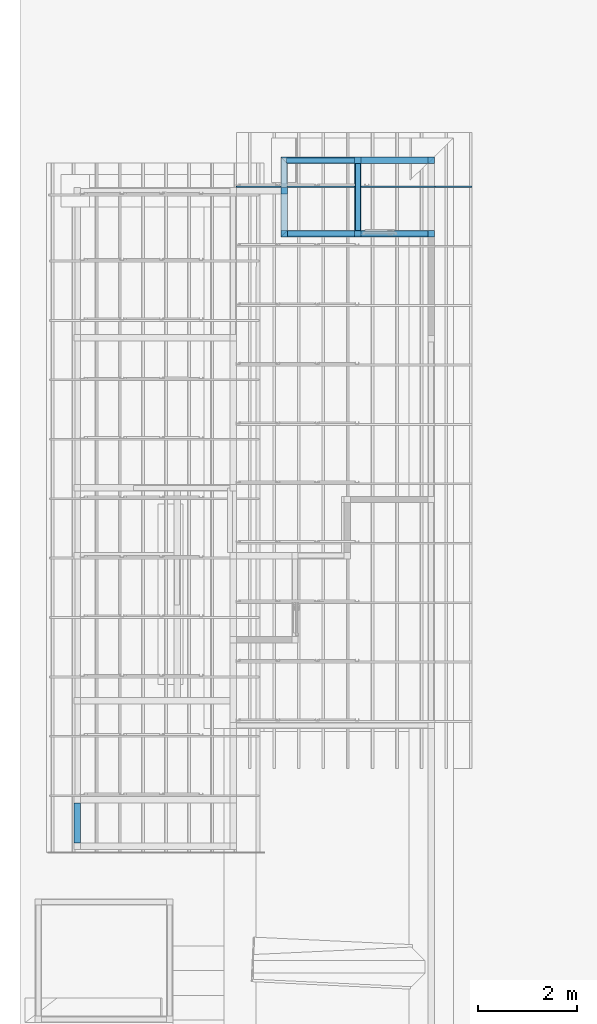
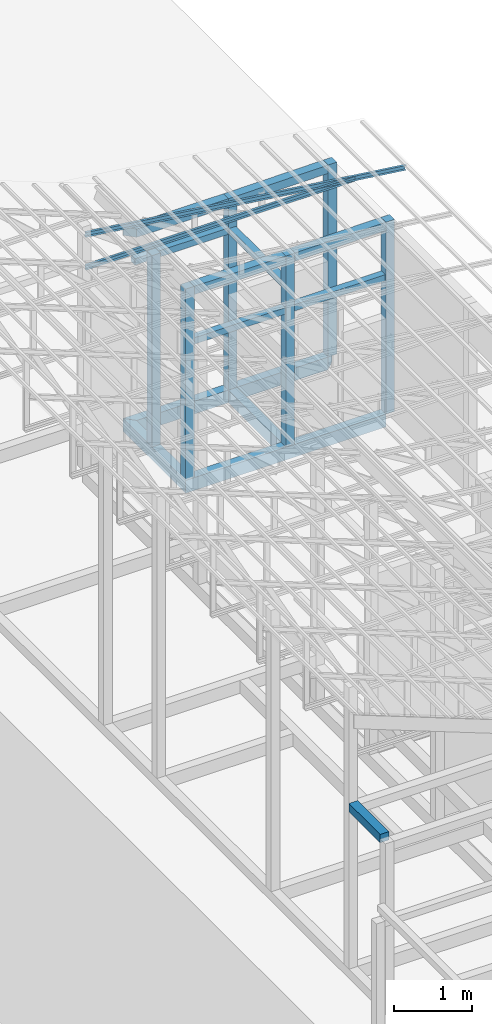
# One storey, part 15 of 22: 18 beams, 2 members, 1 element without a shape of its own.
"""IFC4 building model written with IfcOpenShell, lengths in millimetres."""

from ifc_helpers import new_model, entity, si_unit, converted_unit, frame, origin_with_axes, origin_2d_with_axis, place, context, subcontext, project, spatial, indexed_curve, rectangle, c_section, outline, extrude, clip, halfspace, material, material_profile, profile_set, profile_usage, type_object, element, aggregate, save


model = new_model("IFC4")

# Units and contexts
model_context = context("Model", 3, precision=1e-05, world=origin_with_axes())
plan_context = context("Plan", 2, precision=1e-05, world=origin_2d_with_axis())
body_context = subcontext(model_context, "Body", "Model", "MODEL_VIEW")
ifc_project = project(units=[si_unit("VOLUMEUNIT", "CUBIC_METRE"), si_unit("LENGTHUNIT", "METRE", prefix="MILLI"), si_unit("AREAUNIT", "SQUARE_METRE"), converted_unit("PLANEANGLEUNIT", "degree", entity("IfcReal", 0.0174532925199433), si_unit("PLANEANGLEUNIT", "RADIAN"), dimensions=[0, 0, 0, 0, 0, 0, 0])], contexts=[model_context, plan_context])

# Site, building, storey
site_placement = place(None, origin_with_axes())
site = spatial("IfcSite", under=ifc_project, at=site_placement)
building_placement = place(site_placement, origin_with_axes())
building = spatial("IfcBuilding", under=site, at=building_placement, Name="2")
storey_placement = place(building_placement, frame((0.0, 0.0, 200.000002980232), z_axis=(0.0, 0.0, 1.0), x_axis=(1.0, 0.0, 0.0)))
storey = spatial("IfcBuildingStorey", under=building, at=storey_placement)

# Beams
ifc_material_1 = material(Name="Concrete")
ifc_material_profile_1 = material_profile(ifc_material_1, outline(indexed_curve([(-65.0, 99.9999923706055), (65.0, 99.9999923706055), (65.0, -99.9999923706055), (-65.0, -99.9999923706055), (-65.0, 99.9999923706055)])))
ifc_profile_set_1 = profile_set([ifc_material_profile_1])
ifc_profile_usage_1 = profile_usage(ifc_profile_set_1, cardinal=2)
beam_type_1 = type_object("IfcBeamType", PredefinedType="BEAM", material=ifc_profile_set_1)
beam_1_placement = place(storey_placement, frame((65.0027096271515, 17915.0009155273, -199.99652745696), z_axis=(-0.999999999999962, -1.94707169498535e-07, 1.9470718370939e-07), x_axis=(1.94707183709392e-07, -0.999999999999974, 1.19209289550778e-07)))
element("IfcBeam", 1, at=beam_1_placement, inside=storey, type_object=beam_type_1, material=ifc_profile_usage_1, Name="Beam", PredefinedType="BEAM", context=body_context, shape_type="Clipping", body=[
    clip(clip(extrude(outline(indexed_curve([(-65.0, 99.9999923706055), (65.0, 99.9999923706055), (65.0, -99.9999923706055), (-65.0, -99.9999923706055), (-65.0, 99.9999923706055)])), frame((0.0, 100.0, 0.0), z_axis=(0.0, 0.0, 1.0), x_axis=(1.0, 0.0, 0.0)), (0.0, 0.0, 1.0), 3100.00271335612), halfspace(frame((-65.0011226534843, -0.00514305884280475, 3100.00276565552), z_axis=(0.707104027271271, -1.7982594613386e-07, 0.70710951089859), x_axis=(-2.54313282343768e-07, -0.999999999999968, 0.0)), False)), halfspace(frame((-65.000519156456, -0.00453946859124699, -2.14140332133184e-05), z_axis=(0.707104027271271, 9.55096624011276e-08, -0.70710951089859), x_axis=(1.35071585958435e-07, -0.999999999999991, 0.0)), False)),
])
ifc_profile_usage_2 = profile_usage(ifc_profile_set_1, cardinal=2)
beam_2_placement = place(storey_placement, frame((-2970.00002861023, 17980.001449585, -199.995520159973), z_axis=(-1.8482070629397e-07, -0.999999999995043, -3.14315298054032e-06), x_axis=(0.999999999999983, -1.84820706294883e-07, -1.46446389222155e-14)))
element("IfcBeam", 2, at=beam_2_placement, inside=storey, type_object=beam_type_1, material=ifc_profile_usage_2, Name="Beam", PredefinedType="BEAM", context=body_context, shape_type="Clipping", body=[
    clip(clip(extrude(outline(indexed_curve([(-65.0, 99.9999923706055), (65.0, 99.9999923706055), (65.0, -99.9999923706055), (-65.0, -99.9999923706055), (-65.0, 99.9999923706055)])), frame((0.0, 100.0, 0.0), z_axis=(0.0, 0.0, 1.0), x_axis=(1.0, 0.0, 0.0)), (0.0, 0.0, 1.0), 1610.00063689643), halfspace(frame((-64.999982714653, -0.000398066163143085, 1610.00120639801), z_axis=(0.70710951089859, 2.26468273467617e-06, 0.707104027271271), x_axis=(3.20273267401907e-06, -0.999999999994871, 0.0)), False)), halfspace(frame((-65.0000423192978, -0.00555450560568715, 0.000560934211080166), z_axis=(0.707109272480011, -2.26468364417087e-06, -0.70710426568985), x_axis=(-3.20273504011118e-06, -0.999999999994871, 0.0)), False)),
])
ifc_profile_usage_3 = profile_usage(ifc_profile_set_1, cardinal=2)
beam_3_placement = place(storey_placement, frame((-64.9976283311844, 16435.001373291, -200.000645203886), z_axis=(-0.99999999999995, 4.37114096030178e-08, 3.13916473260163e-07), x_axis=(-4.37113882867378e-08, -0.999999999999997, 5.96046589862452e-08)))
element("IfcBeam", 3, at=beam_3_placement, inside=storey, type_object=beam_type_1, material=ifc_profile_usage_3, Name="Beam", PredefinedType="BEAM", context=body_context, shape_type="Clipping", body=[
    clip(extrude(outline(indexed_curve([(-65.0, 99.9999923706055), (65.0, 99.9999923706055), (65.0, -99.9999923706055), (-65.0, -99.9999923706055), (-65.0, 99.9999923706055)])), frame((0.0, 100.0, 0.0), z_axis=(0.0, 0.0, 1.0), x_axis=(1.0, 0.0, 0.0)), (0.0, 0.0, 1.0), 2970.00272320467), halfspace(frame((65.0006681680679, -0.00126971144709387, 2970.0026512146), z_axis=(-0.707104086875916, -2.21973266434361e-07, 0.707109451293945), x_axis=(-3.13918800010136e-07, 0.999999999999951, 0.0)), False)),
])
ifc_profile_usage_4 = profile_usage(ifc_profile_set_1, cardinal=2)
beam_4_placement = place(storey_placement, frame((-1480.99732398987, 17850.0003814697, -199.995928771386), z_axis=(-1.8482070629397e-07, -0.999999999995043, -3.14315298054032e-06), x_axis=(0.999999999999983, -1.84820706294883e-07, -1.46446389222155e-14)))
element("IfcBeam", 4, at=beam_4_placement, inside=storey, type_object=beam_type_1, material=ifc_profile_usage_4, Name="Beam", PredefinedType="BEAM", context=body_context, shape_type="SweptSolid", body=[
    extrude(outline(indexed_curve([(-65.0, 99.9999923706055), (65.0, 99.9999923706055), (65.0, -99.9999923706055), (-65.0, -99.9999923706055), (-65.0, 99.9999923706055)])), frame((0.0, 100.0, 0.0), z_axis=(0.0, 0.0, 1.0), x_axis=(1.0, 0.0, 0.0)), (0.0, 0.0, 1.0), 1349.99849531971),
])
ifc_material_profile_2 = material_profile(ifc_material_1, rectangle(XDim=130.000015258789, YDim=130.000015258789, kind="CURVE"))
ifc_profile_set_2 = profile_set([ifc_material_profile_2])
ifc_profile_usage_5 = profile_usage(ifc_profile_set_2, cardinal=5)
beam_type_2 = type_object("IfcBeamType", PredefinedType="BEAM", material=ifc_profile_set_2)
beam_5_placement = place(storey_placement, frame((0.00271201133728027, 17915.0009155273, 0.0035017728805542), z_axis=(0.0, 0.0, 1.0), x_axis=(1.0, 0.0, 0.0)))
element("IfcBeam", 5, at=beam_5_placement, inside=storey, type_object=beam_type_2, material=ifc_profile_usage_5, Name="Column", PredefinedType="BEAM", context=body_context, shape_type="SweptSolid", body=[
    extrude(rectangle(XDim=130.000015258789, YDim=130.000015258789, kind="CURVE"), origin_with_axes(), (0.0, 0.0, 1.0), 3010.00737946578),
])
ifc_profile_usage_6 = profile_usage(ifc_profile_set_2, cardinal=2)
beam_6_placement = place(storey_placement, frame((-2970.00002861023, 17234.9987030029, 0.00216066837310791), z_axis=(0.0, 0.0, 1.0), x_axis=(1.0, 0.0, 0.0)))
element("IfcBeam", 6, at=beam_6_placement, inside=storey, type_object=beam_type_2, material=ifc_profile_usage_6, Name="Column", PredefinedType="BEAM", context=body_context, shape_type="SweptSolid", body=[
    extrude(rectangle(XDim=130.000015258789, YDim=130.000015258789, kind="CURVE"), frame((0.0, 65.0000076293945, 0.0), z_axis=(0.0, 0.0, 1.0), x_axis=(1.0, 0.0, 0.0)), (0.0, 0.0, 1.0), 2999.99809265076),
])
ifc_profile_usage_7 = profile_usage(ifc_profile_set_2, cardinal=2)
beam_7_placement = place(storey_placement, frame((-2970.00002861023, 16370.0008392334, 0.000298023223876953), z_axis=(0.0, 0.0, 1.0), x_axis=(1.0, 0.0, 0.0)))
element("IfcBeam", 7, at=beam_7_placement, inside=storey, type_object=beam_type_2, material=ifc_profile_usage_7, Name="Column", PredefinedType="BEAM", context=body_context, shape_type="SweptSolid", body=[
    extrude(rectangle(XDim=130.000015258789, YDim=130.000015258789, kind="CURVE"), frame((0.0, 65.0000076293945, 0.0), z_axis=(0.0, 0.0, 1.0), x_axis=(1.0, 0.0, 0.0)), (0.0, 0.0, 1.0), 3000.0),
])
ifc_profile_usage_8 = profile_usage(ifc_profile_set_2, cardinal=2)
beam_8_placement = place(storey_placement, frame((-1480.99684715271, 16370.0008392334, -0.000134110450744629), z_axis=(0.0, 0.0, 1.0), x_axis=(1.0, 0.0, 0.0)))
element("IfcBeam", 8, at=beam_8_placement, inside=storey, type_object=beam_type_2, material=ifc_profile_usage_8, Name="Column", PredefinedType="BEAM", context=body_context, shape_type="SweptSolid", body=[
    extrude(rectangle(XDim=130.000015258789, YDim=130.000015258789, kind="CURVE"), frame((0.0, 65.0000076293945, 0.0), z_axis=(0.0, 0.0, 1.0), x_axis=(1.0, 0.0, 0.0)), (0.0, 0.0, 1.0), 3000.00079472849),
])
ifc_profile_usage_9 = profile_usage(ifc_profile_set_2, cardinal=2)
beam_9_placement = place(storey_placement, frame((-1480.996966362, 17850.0003814697, 0.00376999378204346), z_axis=(0.0, 0.0, 1.0), x_axis=(1.0, 0.0, 0.0)))
element("IfcBeam", 9, at=beam_9_placement, inside=storey, type_object=beam_type_2, material=ifc_profile_usage_9, Name="Column", PredefinedType="BEAM", context=body_context, shape_type="SweptSolid", body=[
    extrude(rectangle(XDim=130.000015258789, YDim=130.000015258789, kind="CURVE"), frame((0.0, 65.0000076293945, 0.0), z_axis=(0.0, 0.0, 1.0), x_axis=(1.0, 0.0, 0.0)), (0.0, 0.0, 1.0), 2999.99650319214),
])
ifc_profile_usage_10 = profile_usage(ifc_profile_set_2, cardinal=2)
beam_10_placement = place(storey_placement, frame((0.00238418579101562, 16370.0008392334, 0.0031888484954834), z_axis=(0.0, 0.0, 1.0), x_axis=(1.0, 0.0, 0.0)))
element("IfcBeam", 10, at=beam_10_placement, inside=storey, type_object=beam_type_2, material=ifc_profile_usage_10, Name="Column", PredefinedType="BEAM", context=body_context, shape_type="SweptSolid", body=[
    extrude(rectangle(XDim=130.000015258789, YDim=130.000015258789, kind="CURVE"), frame((0.0, 65.0000076293945, 0.0), z_axis=(0.0, 0.0, 1.0), x_axis=(1.0, 0.0, 0.0)), (0.0, 0.0, 1.0), 3010.00785471756),
])
ifc_material_profile_3 = material_profile(ifc_material_1, rectangle(XDim=130.000015258789, YDim=130.000015258789))
ifc_profile_set_3 = profile_set([ifc_material_profile_3])
ifc_profile_usage_11 = profile_usage(ifc_profile_set_3, cardinal=9)
beam_type_3 = type_object("IfcBeamType", Name="Ring", PredefinedType="BEAM", material=ifc_profile_set_3)
beam_11_placement = place(storey_placement, frame((-64.9978592991829, 17979.98046875, 3010.0119560957), z_axis=(-0.999972541750324, 1.42287292919238e-05, -0.00741050220569408), x_axis=(-1.42296166799642e-05, -0.999999999898757, 6.70885000818378e-08)))
element("IfcBeam", 11, at=beam_11_placement, inside=storey, type_object=beam_type_3, material=ifc_profile_usage_11, Name="Beam", context=body_context, shape_type="SweptSolid", body=[
    extrude(rectangle(XDim=130.000015258789, YDim=130.000015258789), frame((65.0000076293945, -65.0000076293945, 0.0), z_axis=(0.0, 0.0, 1.0), x_axis=(1.0, 0.0, 0.0)), (0.0, 0.0, 1.0), 1351.03609377697),
])
ifc_profile_usage_12 = profile_usage(ifc_profile_set_3, cardinal=9)
beam_12_placement = place(storey_placement, frame((-1545.99702358246, 17979.9995422363, 3000.00028312206), z_axis=(-0.999999999999962, -1.94707164287728e-07, 1.94707178498585e-07), x_axis=(1.94707178498587e-07, -0.999999999999974, 1.19209289550778e-07)))
element("IfcBeam", 12, at=beam_12_placement, inside=storey, type_object=beam_type_3, material=ifc_profile_usage_12, Name="Beam", context=body_context, shape_type="Clipping", body=[
    clip(extrude(rectangle(XDim=130.000015258789, YDim=130.000015258789), frame((65.0000076293945, -65.0000076293945, 0.0), z_axis=(0.0, 0.0, 1.0), x_axis=(1.0, 0.0, 0.0)), (0.0, 0.0, 1.0), 1488.97610360693), halfspace(frame((-0.000590931279020879, -3200.00195503235, 1488.97588253021), z_axis=(0.707109987735748, -1.79825207169415e-07, 0.707103729248047), x_axis=(-2.54310093604011e-07, -0.999999999999968, 0.0)), False)),
])
ifc_profile_usage_13 = profile_usage(ifc_profile_set_3, cardinal=9)
beam_13_placement = place(storey_placement, frame((-1415.99678993225, 16370.0008392334, 3000.00052154064), z_axis=(0.999972549563653, 4.45934625726647e-08, 0.00740946146256912), x_axis=(-4.37113899448276e-08, 0.999999999999992, -1.19208472426537e-07)))
element("IfcBeam", 13, at=beam_13_placement, inside=storey, type_object=beam_type_3, material=ifc_profile_usage_13, Name="Beam", context=body_context, shape_type="SweptSolid", body=[
    extrude(rectangle(XDim=130.000015258789, YDim=130.000015258789), frame((65.0000076293945, -65.0000076293945, 0.0), z_axis=(0.0, 0.0, 1.0), x_axis=(1.0, 0.0, 0.0)), (0.0, 0.0, 1.0), 1351.03621716335),
])
ifc_profile_usage_14 = profile_usage(ifc_profile_set_3, cardinal=9)
beam_14_placement = place(storey_placement, frame((-2904.99997138977, 16370.0008392334, 3000.00028312206), z_axis=(0.999999999999798, -3.13916368573315e-07, 5.52335061361681e-07), x_axis=(3.13916482260208e-07, 0.999999999999929, -2.08616253161138e-07)))
element("IfcBeam", 14, at=beam_14_placement, inside=storey, type_object=beam_type_3, material=ifc_profile_usage_14, Name="Beam", context=body_context, shape_type="SweptSolid", body=[
    extrude(rectangle(XDim=130.000015258789, YDim=130.000015258789), frame((65.0000076293945, -65.0000076293945, 0.0), z_axis=(0.0, 0.0, 1.0), x_axis=(1.0, 0.0, 0.0)), (0.0, 0.0, 1.0), 1359.00308190982),
])
ifc_profile_usage_15 = profile_usage(ifc_profile_set_3, cardinal=9)
beam_15_placement = place(storey_placement, frame((-7085.00051498413, 4130.0048828125, 3335.00008285046), z_axis=(-8.74227765734753e-08, 0.999999999999993, 7.54979012640428e-08), x_axis=(-0.999999999999992, -8.74227765734752e-08, 8.74227836789026e-08)))
element("IfcBeam", 15, at=beam_15_placement, inside=storey, type_object=beam_type_3, material=ifc_profile_usage_15, Name="Beam", context=body_context, shape_type="SweptSolid", body=[
    extrude(rectangle(XDim=130.000015258789, YDim=130.000015258789), frame((65.0000076293945, -65.0000076293945, 0.0), z_axis=(0.0, 0.0, 1.0), x_axis=(1.0, 0.0, 0.0)), (0.0, 0.0, 1.0), 804.992691978312),
])

# Assembly, members
assembly_placement = place(storey_placement, frame((-1561.45393848419, 6600.0657081604, 3019.63977515697), z_axis=(0.0, 0.0, 1.0), x_axis=(1.0, 0.0, 0.0)))
assembly = element("IfcElementAssembly", 16, at=assembly_placement, inside=storey, Name="K1")
ifc_material_2 = material(Name="STEEL")
ifc_material_profile_4 = material_profile(ifc_material_2, c_section(Depth=75.0, Width=35.0, WallThickness=1.0, Girth=1.0, kind="CURVE"))
ifc_profile_set_4 = profile_set([ifc_material_profile_4])
ifc_profile_usage_16 = profile_usage(ifc_profile_set_4, cardinal=9)
member_type = type_object("IfcMemberType", Name="C75", PredefinedType="CHORD", material=ifc_profile_set_4)
member_1_placement = place(assembly_placement, frame((1634.4433426857, 10798.9325523376, 64.9838447570801), z_axis=(-0.999999999999996, -7.54978941586157e-08, -4.37113882867378e-08), x_axis=(7.54979012640425e-08, -0.999999999999989, -1.2785038450147e-07)))
member_1 = element("IfcMember", 17, at=member_1_placement, type_object=member_type, material=ifc_profile_usage_16, Name="Member", context=body_context, shape_type="SweptSolid", body=[
    extrude(c_section(Depth=75.0, Width=35.0, WallThickness=1.0, Girth=1.0, kind="CURVE"), frame((17.5, -37.5, 0.0), z_axis=(0.0, 0.0, 1.0), x_axis=(1.0, 0.0, 0.0)), (0.0, 0.0, 1.0), 4007.95455591631),
])
ifc_profile_usage_17 = profile_usage(ifc_profile_set_4, cardinal=9)
member_2_placement = place(assembly_placement, frame((2381.98524713516, 10798.9325523376, -28.5120010375977), z_axis=(-0.991864132670109, -9.11591360127481e-08, 0.127300991050989), x_axis=(7.54979012640425e-08, -0.999999999999989, -1.2785038450147e-07)))
member_2 = element("IfcMember", 18, at=member_2_placement, type_object=member_type, material=ifc_profile_usage_17, Name="Member", context=body_context, shape_type="SweptSolid", body=[
    extrude(c_section(Depth=75.0, Width=35.0, WallThickness=1.0, Girth=1.0, kind="CURVE"), frame((17.5, -37.5, 0.0), z_axis=(0.0, 0.0, 1.0), x_axis=(1.0, 0.0, 0.0)), (0.0, 0.0, 1.0), 4790.46084290085),
])
aggregate(assembly, [member_1, member_2])

# Beams
ifc_material_profile_5 = material_profile(ifc_material_1, rectangle(XDim=100.0, YDim=100.0))
ifc_profile_set_5 = profile_set([ifc_material_profile_5])
ifc_profile_usage_18 = profile_usage(ifc_profile_set_5, cardinal=2)
beam_type_4 = type_object("IfcBeamType", PredefinedType="BEAM", material=ifc_profile_set_5)
beam_16_placement = place(storey_placement, frame((-1545.99666595459, 17915.0009155273, 2430.00416457653), z_axis=(-0.999999999999962, -1.94707169498535e-07, 1.9470718370939e-07), x_axis=(1.94707183709392e-07, -0.999999999999974, 1.19209289550778e-07)))
element("IfcBeam", 19, at=beam_16_placement, inside=storey, type_object=beam_type_4, material=ifc_profile_usage_18, Name="Beam", PredefinedType="BEAM", context=body_context, shape_type="SweptSolid", body=[
    extrude(rectangle(XDim=100.0, YDim=100.0), frame((0.0, 50.0, 0.0), z_axis=(0.0, 0.0, 1.0), x_axis=(1.0, 0.0, 0.0)), (0.0, 0.0, 1.0), 1374.00339595927),
])
ifc_profile_usage_19 = profile_usage(ifc_profile_set_5, cardinal=2)
beam_17_placement = place(storey_placement, frame((-64.9976283311844, 16435.001373291, 2079.9992531538), z_axis=(-0.99999999999995, 4.37114096030178e-08, 3.13916473260163e-07), x_axis=(-4.37113882867378e-08, -0.999999999999997, 5.96046589862452e-08)))
element("IfcBeam", 20, at=beam_17_placement, inside=storey, type_object=beam_type_4, material=ifc_profile_usage_19, Name="Beam", PredefinedType="BEAM", context=body_context, shape_type="SweptSolid", body=[
    extrude(rectangle(XDim=100.0, YDim=100.0), frame((0.0, 50.0, 0.0), z_axis=(0.0, 0.0, 1.0), x_axis=(1.0, 0.0, 0.0)), (0.0, 0.0, 1.0), 2840.00258808303),
])
ifc_profile_usage_20 = profile_usage(ifc_profile_set_5, cardinal=2)
beam_18_placement = place(storey_placement, frame((-1480.99732398987, 17850.0003814697, 2430.00416457653), z_axis=(-1.8482070629397e-07, -0.999999999995043, -3.14315298054032e-06), x_axis=(0.999999999999983, -1.84820706294883e-07, -1.46446389222155e-14)))
element("IfcBeam", 21, at=beam_18_placement, inside=storey, type_object=beam_type_4, material=ifc_profile_usage_20, Name="Beam", PredefinedType="BEAM", context=body_context, shape_type="SweptSolid", body=[
    extrude(rectangle(XDim=100.0, YDim=100.0), frame((0.0, 50.0, 0.0), z_axis=(0.0, 0.0, 1.0), x_axis=(1.0, 0.0, 0.0)), (0.0, 0.0, 1.0), 1349.99849531986),
])

save(model, "model.ifc")
